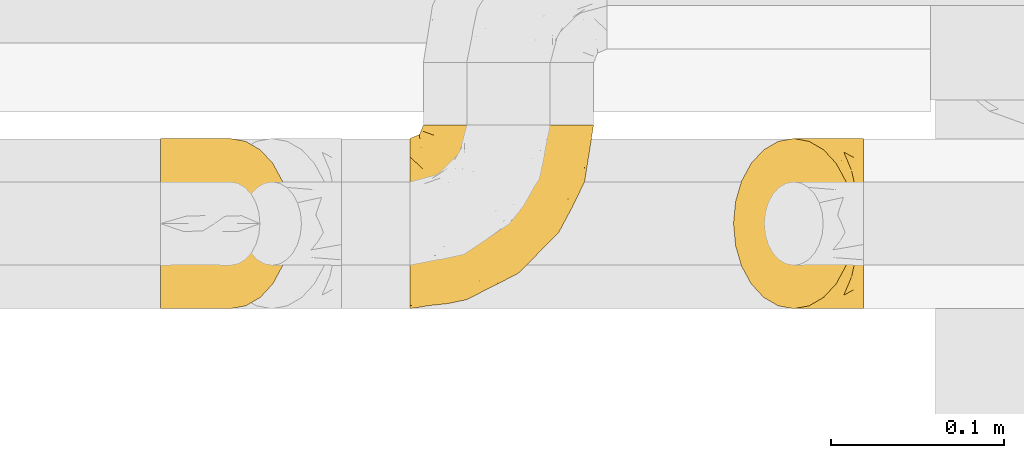
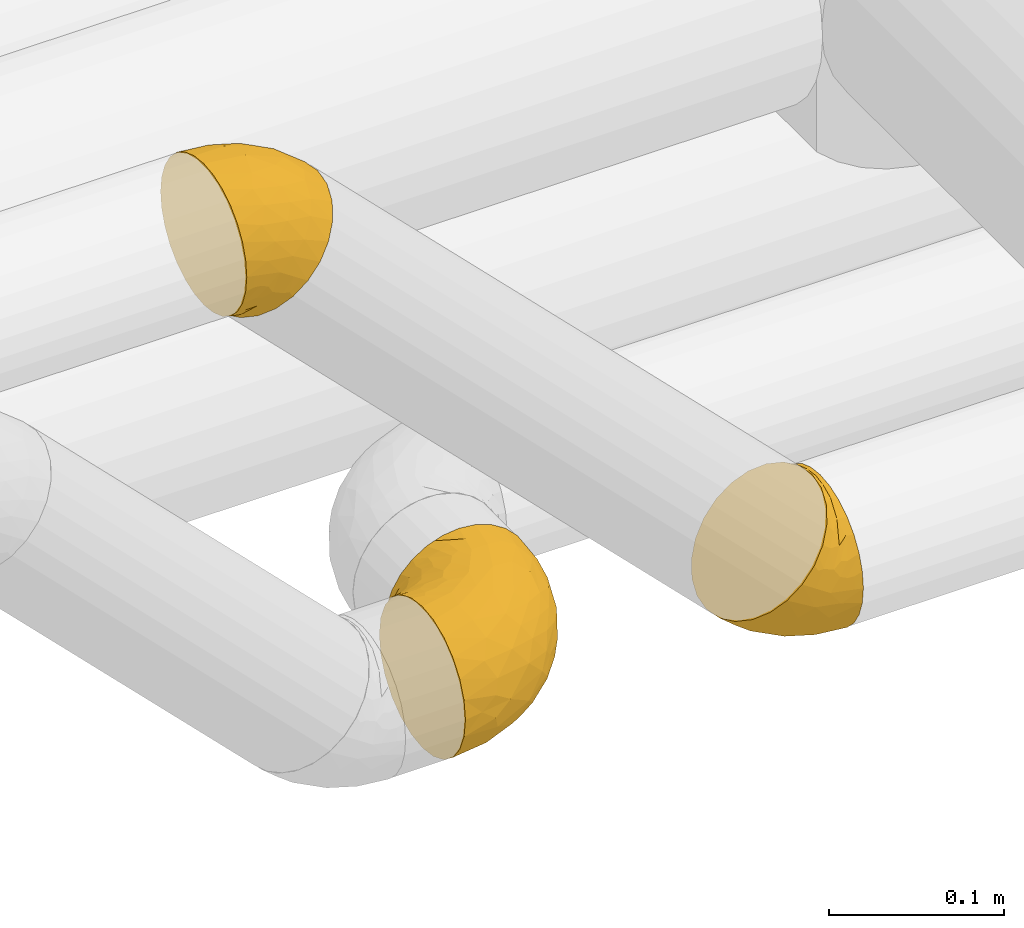
# One storey, part 31 of 93: 3 coverings.
"""IFC2X3 building model written with IfcOpenShell, lengths in millimetres."""

from ifc_helpers import new_model, entity, si_unit, converted_unit, derived_unit, direction, frame, origin, place, context, subcontext, project, spatial, faceted_brep, element, save


model = new_model("IFC2X3")

# Units and contexts
model_context = context("Model", 3, precision=0.01, world=origin(), true_north=direction((6.12303176911189e-17, 1.0)))
body_context = subcontext(model_context, "Body", "Model", "MODEL_VIEW")
ifc_project = project(units=[si_unit("LENGTHUNIT", "METRE", prefix="MILLI"), si_unit("AREAUNIT", "SQUARE_METRE"), si_unit("VOLUMEUNIT", "CUBIC_METRE"), converted_unit("PLANEANGLEUNIT", "DEGREE", entity("IfcRatioMeasure", 0.0174532925199433), si_unit("PLANEANGLEUNIT", "RADIAN"), dimensions=[0, 0, 0, 0, 0, 0, 0]), si_unit("MASSUNIT", "GRAM", prefix="KILO"), derived_unit("MASSDENSITYUNIT", [(si_unit("MASSUNIT", "GRAM", prefix="KILO"), 1), (si_unit("LENGTHUNIT", "METRE"), -3)]), derived_unit("MOMENTOFINERTIAUNIT", [(si_unit("LENGTHUNIT", "METRE"), 4)]), si_unit("TIMEUNIT", "SECOND"), si_unit("FREQUENCYUNIT", "HERTZ"), si_unit("THERMODYNAMICTEMPERATUREUNIT", "DEGREE_CELSIUS"), derived_unit("THERMALTRANSMITTANCEUNIT", [(si_unit("MASSUNIT", "GRAM", prefix="KILO"), 1), (si_unit("THERMODYNAMICTEMPERATUREUNIT", "KELVIN"), -1), (si_unit("TIMEUNIT", "SECOND"), -3)]), derived_unit("VOLUMETRICFLOWRATEUNIT", [(si_unit("LENGTHUNIT", "METRE"), 3), (si_unit("TIMEUNIT", "SECOND"), -1)]), derived_unit("MASSFLOWRATEUNIT", [(si_unit("MASSUNIT", "GRAM", prefix="KILO"), 1), (si_unit("TIMEUNIT", "SECOND"), -1)]), derived_unit("ROTATIONALFREQUENCYUNIT", [(si_unit("TIMEUNIT", "SECOND"), -1)]), si_unit("ELECTRICCURRENTUNIT", "AMPERE"), si_unit("ELECTRICVOLTAGEUNIT", "VOLT"), si_unit("POWERUNIT", "WATT"), si_unit("FORCEUNIT", "NEWTON", prefix="KILO"), si_unit("ILLUMINANCEUNIT", "LUX"), si_unit("LUMINOUSFLUXUNIT", "LUMEN"), si_unit("LUMINOUSINTENSITYUNIT", "CANDELA"), derived_unit("USERDEFINED", [(si_unit("MASSUNIT", "GRAM", prefix="KILO"), -1), (si_unit("LENGTHUNIT", "METRE"), -2), (si_unit("TIMEUNIT", "SECOND"), 3), (si_unit("LUMINOUSFLUXUNIT", "LUMEN"), 1)]), derived_unit("LINEARVELOCITYUNIT", [(si_unit("LENGTHUNIT", "METRE"), 1), (si_unit("TIMEUNIT", "SECOND"), -1)]), si_unit("PRESSUREUNIT", "PASCAL"), derived_unit("USERDEFINED", [(si_unit("LENGTHUNIT", "METRE"), -2), (si_unit("MASSUNIT", "GRAM", prefix="KILO"), 1), (si_unit("TIMEUNIT", "SECOND"), -2)]), derived_unit("LINEARFORCEUNIT", [(si_unit("MASSUNIT", "GRAM", prefix="KILO"), 1), (si_unit("LENGTHUNIT", "METRE"), 1), (si_unit("TIMEUNIT", "SECOND"), -2), (si_unit("LENGTHUNIT", "METRE"), -1)]), derived_unit("PLANARFORCEUNIT", [(si_unit("MASSUNIT", "GRAM", prefix="KILO"), 1), (si_unit("LENGTHUNIT", "METRE"), 1), (si_unit("TIMEUNIT", "SECOND"), -2), (si_unit("LENGTHUNIT", "METRE"), -2)])], contexts=[model_context])

# Site, building, storey
site_placement = place(None, origin())
site = spatial("IfcSite", under=ifc_project, at=site_placement, CompositionType="ELEMENT")
building_placement = place(site_placement, origin())
building = spatial("IfcBuilding", under=site, at=building_placement, CompositionType="ELEMENT")
storey_placement = place(building_placement, frame((0.0, 0.0, -4200.0)))
storey = spatial("IfcBuildingStorey", under=building, at=storey_placement, CompositionType="ELEMENT", Elevation=-4200.0)

# Coverings
covering_1_placement = place(storey_placement, frame((23794.45, 8660.4, 2649.25)))
element("IfcCovering", 1, at=covering_1_placement, inside=storey, Name=":ADSK_", ObjectType=":ADSK_", PredefinedType="INSULATION", context=body_context, shape_type="Brep", body=[
    faceted_brep([(58.6, 107.75, 99.9), (69.54, 107.75, 98.66), (79.93, 107.75, 95.02), (89.25, 107.75, 89.17), (97.03, 107.75, 81.38), (102.88, 107.75, 72.06), (106.51, 107.75, 61.68), (107.75, 107.75, 50.75), (106.51, 107.75, 39.8), (102.87, 107.75, 29.41), (97.02, 107.75, 20.09), (89.23, 107.75, 12.31), (79.91, 107.75, 6.46), (69.53, 107.75, 2.83), (58.6, 107.75, 1.6), (52.89, 107.75, 2.24), (47.65, 107.75, 2.83), (42.46, 107.75, 4.65), (37.26, 107.75, 6.47), (27.94, 107.75, 12.32), (20.16, 107.75, 20.11), (14.31, 107.75, 29.43), (10.68, 107.75, 39.81), (9.45, 107.75, 50.75), (10.68, 107.75, 61.69), (14.32, 107.75, 72.08), (20.17, 107.75, 81.4), (27.96, 107.75, 89.18), (37.28, 107.75, 95.03), (42.47, 107.75, 96.85), (47.66, 107.75, 98.66), (52.89, 107.75, 99.25), (55.75, 107.75, 99.57), (1.6, 98.22, 38.02), (1.6, 93.31, 26.17), (1.6, 89.4, 21.08), (1.6, 85.5, 15.99), (1.6, 80.41, 12.09), (1.6, 75.32, 8.18), (1.6, 69.39, 5.73), (1.6, 63.47, 3.27), (1.6, 56.48, 2.35), (1.6, 53.61, 1.97), (1.6, 50.75, 1.6), (1.6, 38.02, 3.27), (1.6, 26.17, 8.18), (1.6, 15.99, 15.99), (1.6, 8.18, 26.17), (1.6, 3.27, 38.02), (1.6, 1.6, 50.75), (1.6, 3.27, 63.47), (1.6, 8.18, 75.32), (1.6, 15.99, 85.5), (1.6, 26.17, 93.31), (1.6, 38.02, 98.22), (1.6, 50.75, 99.9), (1.6, 56.48, 99.14), (1.6, 63.47, 98.22), (1.6, 69.39, 95.77), (1.6, 75.32, 93.31), (1.6, 80.41, 89.4), (1.6, 85.5, 85.5), (1.6, 89.4, 80.41), (1.6, 93.31, 75.32), (1.6, 98.22, 63.47), (1.6, 99.9, 50.75), (69.96, 27.53, 59.31), (59.59, 25.32, 73.08), (51.96, 16.29, 63.72), (34.4, 6.79, 50.75), (23.37, 4.51, 58.64), (13.68, 3.51, 50.75), (41.52, 17.47, 76.74), (26.26, 7.6, 67.68), (20.18, 12.27, 78.92), (72.33, 70.89, 94.31), (65.88, 87.17, 98.76), (57.55, 67.3, 98.4), (23.76, 31.65, 94.57), (46.5, 33.58, 89.91), (46.57, 47.23, 96.32), (21.17, 43.26, 98.79), (23.41, 55.08, 99.9), (17.92, 53.99, 99.9), (12.43, 52.9, 99.9), (9.72, 52.36, 99.9), (7.01, 51.82, 99.9), (26.77, 21.5, 87.31), (76.59, 89.94, 95.61), (95.55, 60.45, 60.43), (102.57, 83.0, 65.24), (92.89, 64.79, 72.87), (54.26, 85.93, 99.9), (51.17, 81.31, 99.9), (48.08, 76.69, 99.9), (44.99, 72.06, 99.9), (41.9, 67.44, 99.9), (85.16, 88.74, 90.65), (85.97, 45.98, 63.14), (59.58, 47.13, 91.89), (99.5, 89.4, 75.25), (105.83, 95.66, 50.75), (53.59, 28.5, 82.18), (67.0, 42.81, 85.08), (71.56, 38.28, 76.93), (87.47, 45.35, 50.75), (75.73, 33.61, 50.75), (92.24, 82.57, 83.02), (58.06, 105.04, 99.9), (57.52, 102.33, 99.9), (56.44, 96.91, 99.9), (55.35, 91.42, 99.9), (81.33, 65.92, 87.13), (80.35, 53.11, 80.85), (39.44, 54.37, 99.17), (102.55, 74.94, 50.75), (37.28, 64.35, 99.9), (32.65, 61.26, 99.9), (28.03, 58.17, 99.9), (63.99, 21.87, 50.75), (74.55, 34.79, 67.61), (83.62, 48.48, 72.25), (95.01, 60.15, 50.75), (49.19, 14.33, 50.75), (46.96, 99.07, 98.69), (8.77, 60.55, 99.01), (18.28, 64.18, 98.79), (11.68, 64.36, 98.29), (11.79, 103.17, 68.51), (15.69, 101.69, 76.82), (42.49, 87.75, 98.54), (47.41, 89.38, 99.3), (7.94, 88.34, 83.57), (9.27, 82.14, 89.47), (7.98, 94.51, 75.76), (13.4, 89.64, 84.86), (13.04, 98.41, 75.89), (7.36, 99.71, 64.77), (23.46, 89.37, 90.83), (30.46, 88.21, 94.62), (26.54, 95.2, 90.37), (6.76, 79.14, 91.18), (26.46, 101.22, 88.65), (20.77, 99.41, 84.11), (20.68, 84.72, 91.75), (40.26, 97.47, 96.86), (7.15, 102.19, 50.75), (9.28, 104.02, 58.97), (38.78, 82.66, 98.37), (18.27, 95.42, 83.91), (31.78, 78.67, 97.52), (12.75, 72.69, 95.55), (22.96, 66.46, 98.76), (17.55, 75.3, 95.26), (27.63, 72.74, 98.04), (15.23, 82.93, 90.65), (33.25, 99.27, 93.51), (32.43, 93.51, 94.16), (27.9, 67.35, 99.1), (7.97, 94.51, 25.73), (15.22, 82.94, 10.84), (7.93, 88.33, 17.92), (13.38, 89.64, 16.64), (13.12, 103.62, 30.44), (42.49, 87.74, 2.95), (47.4, 89.38, 2.19), (51.17, 81.31, 1.6), (40.24, 97.47, 4.63), (20.76, 99.41, 17.39), (12.43, 52.9, 1.6), (7.01, 51.82, 1.6), (4.31, 51.28, 1.6), (26.44, 101.21, 12.86), (26.52, 95.19, 11.13), (11.68, 64.36, 3.2), (12.75, 72.69, 5.94), (9.27, 82.13, 12.02), (17.55, 75.3, 6.23), (6.76, 79.14, 10.31), (33.21, 99.28, 8.0), (32.41, 93.51, 7.34), (8.77, 60.55, 2.48), (22.96, 66.46, 2.73), (18.48, 63.96, 2.64), (56.44, 96.91, 1.6), (46.95, 99.06, 2.8), (7.36, 99.7, 36.71), (17.92, 53.99, 1.6), (23.41, 55.08, 1.6), (9.85, 103.3, 38.59), (57.52, 102.33, 1.6), (56.98, 99.62, 1.6), (48.08, 76.69, 1.6), (38.78, 82.66, 3.12), (18.25, 95.42, 17.59), (44.99, 72.06, 1.6), (31.74, 78.68, 3.98), (30.45, 88.2, 6.87), (27.63, 72.75, 3.45), (20.65, 84.74, 9.76), (55.35, 91.42, 1.6), (54.26, 85.93, 1.6), (13.03, 98.41, 25.62), (23.44, 89.37, 10.67), (27.9, 67.35, 2.39), (32.65, 61.26, 1.6), (28.03, 58.17, 1.6), (37.28, 64.35, 1.6), (41.9, 67.44, 1.6), (39.74, 54.08, 2.4), (23.37, 4.51, 42.85), (26.77, 21.5, 14.18), (46.18, 33.43, 11.56), (53.54, 28.5, 19.27), (41.53, 17.47, 24.75), (59.61, 25.36, 28.37), (76.79, 90.18, 5.95), (66.11, 86.97, 2.79), (21.17, 43.26, 2.71), (51.96, 16.29, 37.78), (26.26, 7.6, 33.81), (20.18, 12.27, 22.57), (23.76, 31.65, 6.92), (92.88, 64.79, 28.61), (102.57, 83.0, 36.24), (95.54, 60.44, 41.05), (71.63, 38.35, 24.55), (74.55, 34.8, 33.88), (72.51, 71.54, 7.11), (69.96, 27.53, 42.18), (92.23, 82.57, 18.46), (85.15, 88.74, 10.84), (80.45, 53.19, 20.69), (83.65, 48.49, 29.27), (57.57, 67.28, 3.1), (63.68, 52.32, 9.18), (85.95, 45.94, 38.38), (99.49, 89.4, 26.23), (81.23, 65.75, 14.34), (47.07, 46.73, 5.46), (66.99, 42.82, 16.39)], [[[0, 1, 2, 3, 4, 5, 6, 7, 8, 9, 10, 11, 12, 13, 14, 15, 16, 17, 18, 19, 20, 21, 22, 23, 24, 25, 26, 27, 28, 29, 30, 31, 32]], [[33, 34, 35, 36, 37, 38, 39, 40, 41, 42, 43, 44, 45, 46, 47, 48, 49, 50, 51, 52, 53, 54, 55, 56, 57, 58, 59, 60, 61, 62, 63, 64, 65]], [[66, 67, 68]], [[69, 70, 71]], [[68, 72, 73]], [[73, 72, 74]], [[75, 76, 77]], [[78, 79, 80]], [[51, 50, 73]], [[81, 82, 83, 84, 85, 86, 55]], [[52, 87, 53]], [[74, 52, 51]], [[2, 1, 88]], [[89, 90, 91]], [[77, 92, 93, 94, 95, 96]], [[55, 54, 81]], [[78, 53, 87]], [[5, 90, 6]], [[88, 76, 75]], [[97, 3, 2]], [[89, 91, 98]], [[99, 80, 79]], [[90, 5, 100]], [[74, 87, 52]], [[100, 5, 4]], [[90, 101, 6]], [[79, 102, 103]], [[102, 67, 104]], [[105, 98, 106]], [[107, 4, 3]], [[76, 0, 108, 109, 110, 111, 92]], [[107, 112, 113]], [[114, 77, 96]], [[89, 115, 90]], [[114, 96, 116, 117, 118, 82]], [[75, 97, 88]], [[119, 66, 68]], [[50, 71, 70]], [[100, 91, 90]], [[99, 77, 80]], [[102, 104, 103]], [[97, 107, 3]], [[80, 81, 78]], [[107, 97, 112]], [[68, 73, 70]], [[66, 98, 120]], [[78, 81, 54]], [[114, 81, 80]], [[53, 78, 54]], [[78, 87, 79]], [[102, 87, 72]], [[79, 103, 99]], [[4, 107, 100]], [[91, 100, 107]], [[88, 97, 2]], [[112, 97, 75]], [[99, 112, 75]], [[103, 104, 113]], [[91, 121, 98]], [[89, 105, 122, 115]], [[101, 90, 115]], [[101, 7, 6]], [[88, 1, 76]], [[0, 76, 1]], [[92, 77, 76]], [[73, 74, 51]], [[87, 74, 72]], [[81, 114, 82]], [[77, 114, 80]], [[87, 102, 79]], [[67, 102, 72]], [[68, 67, 72]], [[67, 120, 104]], [[120, 121, 104]], [[104, 121, 113]], [[121, 120, 98]], [[91, 107, 113]], [[91, 113, 121]], [[103, 113, 112]], [[106, 98, 66]], [[105, 89, 98]], [[106, 66, 119]], [[67, 66, 120]], [[68, 69, 123, 119]], [[50, 49, 71]], [[50, 70, 73]], [[112, 99, 103]], [[77, 99, 75]], [[69, 68, 70]], [[29, 124, 110]], [[84, 83, 125]], [[126, 82, 118]], [[59, 58, 127]], [[25, 128, 129]], [[130, 93, 131]], [[132, 62, 133]], [[134, 135, 136]], [[137, 65, 64]], [[64, 134, 137]], [[138, 139, 140]], [[111, 110, 124, 92]], [[134, 136, 137]], [[134, 64, 63]], [[141, 61, 60]], [[125, 58, 57]], [[142, 143, 140]], [[142, 26, 143]], [[127, 83, 82]], [[28, 124, 29]], [[108, 0, 32, 31, 30, 110, 109]], [[30, 29, 110]], [[135, 144, 138]], [[28, 145, 124]], [[57, 56, 55, 86, 85, 84]], [[146, 147, 23]], [[24, 23, 147]], [[25, 143, 26]], [[95, 94, 148]], [[24, 128, 25]], [[149, 138, 143]], [[124, 145, 131]], [[127, 58, 125]], [[150, 148, 139]], [[127, 126, 151]], [[151, 59, 127]], [[152, 151, 126]], [[153, 154, 155]], [[153, 133, 141]], [[145, 28, 27]], [[142, 156, 27]], [[157, 148, 130]], [[61, 133, 62]], [[134, 132, 135]], [[147, 128, 24]], [[65, 137, 146]], [[146, 137, 147]], [[128, 137, 136]], [[137, 128, 147]], [[128, 136, 129]], [[149, 129, 136]], [[25, 129, 143]], [[158, 152, 117]], [[152, 118, 117]], [[153, 151, 152]], [[158, 116, 154]], [[144, 150, 138]], [[153, 152, 158]], [[133, 153, 155]], [[133, 155, 132]], [[60, 151, 141]], [[135, 132, 155]], [[134, 63, 132]], [[144, 135, 155]], [[135, 138, 149]], [[155, 154, 144]], [[150, 154, 96]], [[154, 150, 144]], [[148, 94, 130]], [[82, 126, 127]], [[118, 152, 126]], [[150, 96, 95]], [[139, 148, 157]], [[150, 95, 148]], [[93, 92, 131]], [[130, 145, 156]], [[130, 94, 93]], [[84, 125, 57]], [[127, 125, 83]], [[140, 139, 157]], [[150, 139, 138]], [[140, 157, 142]], [[138, 140, 143]], [[156, 142, 157]], [[27, 26, 142]], [[130, 156, 157]], [[145, 27, 156]], [[132, 63, 62]], [[124, 131, 92]], [[130, 131, 145]], [[129, 149, 143]], [[135, 149, 136]], [[141, 133, 61]], [[60, 59, 151]], [[141, 151, 153]], [[116, 96, 154]], [[153, 158, 154]], [[158, 117, 116]], [[34, 33, 159]], [[160, 161, 162]], [[22, 21, 163]], [[164, 165, 166]], [[19, 18, 167]], [[168, 21, 20]], [[42, 41, 40, 169, 170, 171, 43]], [[172, 173, 168]], [[174, 38, 175]], [[176, 177, 178]], [[179, 164, 180]], [[40, 181, 169]], [[182, 183, 175]], [[17, 184, 185]], [[65, 146, 186]], [[187, 174, 188]], [[23, 22, 189]], [[174, 39, 38]], [[15, 14, 190, 191, 184, 16]], [[181, 40, 39]], [[192, 193, 164]], [[194, 163, 168]], [[33, 186, 159]], [[180, 173, 172]], [[195, 196, 193]], [[18, 185, 167]], [[173, 180, 197]], [[198, 199, 196]], [[200, 201, 185, 184]], [[184, 17, 16]], [[18, 17, 185]], [[202, 159, 186]], [[194, 168, 203]], [[189, 163, 202]], [[204, 205, 182]], [[187, 181, 174]], [[160, 177, 176]], [[206, 183, 182]], [[206, 182, 205]], [[201, 165, 185]], [[165, 164, 167]], [[172, 179, 180]], [[202, 194, 162]], [[176, 161, 160]], [[65, 186, 33]], [[163, 189, 22]], [[175, 177, 182]], [[174, 183, 188]], [[177, 198, 204]], [[199, 160, 162]], [[198, 207, 204]], [[175, 38, 37]], [[198, 177, 160]], [[178, 177, 175]], [[176, 35, 161]], [[34, 159, 161]], [[162, 161, 159]], [[202, 162, 159]], [[199, 162, 203]], [[196, 199, 203]], [[198, 160, 199]], [[193, 197, 180]], [[208, 198, 196]], [[188, 183, 206]], [[175, 183, 174]], [[193, 192, 195]], [[195, 208, 196]], [[197, 196, 203]], [[180, 164, 193]], [[168, 163, 21]], [[166, 165, 201]], [[166, 192, 164]], [[189, 202, 186]], [[186, 146, 189]], [[23, 189, 146]], [[174, 181, 39]], [[169, 181, 187]], [[196, 197, 193]], [[173, 203, 168]], [[203, 173, 197]], [[172, 168, 20]], [[20, 19, 172]], [[179, 172, 19]], [[19, 167, 179]], [[164, 179, 167]], [[35, 176, 36]], [[35, 34, 161]], [[185, 165, 167]], [[162, 194, 203]], [[163, 194, 202]], [[176, 178, 36]], [[37, 36, 178]], [[175, 37, 178]], [[177, 204, 182]], [[207, 198, 208]], [[207, 205, 204]], [[209, 188, 206, 205, 207, 208]], [[48, 210, 71]], [[211, 212, 213]], [[214, 213, 215]], [[216, 217, 13]], [[218, 43, 171, 170, 169, 187, 188]], [[219, 220, 214]], [[47, 46, 221]], [[210, 48, 220]], [[211, 222, 212]], [[222, 45, 44]], [[221, 220, 47]], [[47, 220, 48]], [[221, 211, 214]], [[223, 224, 225]], [[211, 46, 45]], [[226, 227, 215]], [[43, 218, 44]], [[217, 216, 228]], [[219, 215, 229]], [[14, 13, 217]], [[224, 9, 8]], [[10, 230, 11]], [[11, 231, 12]], [[232, 223, 233]], [[234, 208, 195, 192, 166, 201]], [[235, 234, 228]], [[222, 44, 218]], [[106, 229, 236]], [[224, 237, 9]], [[231, 238, 228]], [[9, 237, 10]], [[115, 224, 101]], [[239, 234, 235]], [[231, 11, 230]], [[223, 230, 237]], [[224, 8, 101]], [[223, 236, 233]], [[225, 115, 122, 105]], [[216, 12, 231]], [[209, 234, 239]], [[210, 219, 69]], [[219, 214, 215]], [[229, 119, 219]], [[209, 218, 188]], [[239, 212, 222]], [[239, 222, 218]], [[45, 222, 211]], [[235, 212, 239]], [[213, 212, 240]], [[223, 237, 224]], [[230, 10, 237]], [[238, 231, 230]], [[216, 231, 228]], [[232, 230, 223]], [[235, 238, 240]], [[115, 225, 224]], [[233, 236, 227]], [[8, 7, 101]], [[234, 209, 208]], [[218, 209, 239]], [[217, 228, 234]], [[13, 12, 216]], [[234, 201, 217]], [[217, 201, 200, 184, 191, 190, 14]], [[211, 221, 46]], [[220, 221, 214]], [[71, 210, 69]], [[71, 49, 48]], [[219, 210, 220]], [[226, 215, 213]], [[211, 213, 214]], [[226, 213, 240]], [[215, 227, 229]], [[232, 240, 238]], [[233, 227, 226]], [[232, 233, 226]], [[236, 223, 225]], [[240, 232, 226]], [[232, 238, 230]], [[225, 105, 236]], [[236, 105, 106]], [[236, 229, 227]], [[123, 69, 219, 119]], [[106, 119, 229]], [[238, 235, 228]], [[212, 235, 240]]]),
])
covering_2_placement = place(storey_placement, frame((23650.45, 8660.4, 3005.76)))
element("IfcCovering", 2, at=covering_2_placement, inside=storey, Name=":ADSK_", ObjectType=":ADSK_", PredefinedType="INSULATION", context=body_context, shape_type="Brep", body=[
    faceted_brep([(1.6, 50.75, 3.89), (1.6, 39.8, 5.13), (1.6, 29.41, 8.77), (1.6, 20.09, 14.62), (1.6, 12.31, 22.41), (1.6, 6.46, 31.73), (1.6, 2.83, 42.11), (1.6, 1.6, 53.04), (1.6, 2.83, 63.99), (1.6, 6.47, 74.38), (1.6, 12.32, 83.7), (1.6, 20.11, 91.48), (1.6, 29.43, 97.33), (1.6, 39.81, 100.96), (1.6, 50.75, 102.19), (1.6, 61.69, 100.96), (1.6, 72.08, 97.32), (1.6, 81.4, 91.47), (1.6, 89.18, 83.68), (1.6, 95.03, 74.36), (1.6, 98.66, 63.98), (1.6, 99.9, 53.04), (1.6, 98.66, 42.1), (1.6, 95.02, 31.71), (1.6, 89.17, 22.39), (1.6, 81.38, 14.61), (1.6, 72.06, 8.76), (1.6, 61.68, 5.13), (8.33, 63.47, 2.78), (11.8, 75.32, 6.25), (17.33, 85.5, 11.77), (24.52, 93.31, 18.97), (32.91, 98.22, 27.35), (35.62, 98.73, 30.07), (41.9, 99.9, 36.35), (50.9, 98.22, 45.34), (59.28, 93.31, 53.73), (66.48, 85.5, 60.92), (72.0, 75.32, 66.45), (75.47, 63.47, 69.92), (76.65, 50.75, 71.1), (75.47, 38.02, 69.92), (72.0, 26.17, 66.45), (66.48, 15.99, 60.92), (59.28, 8.18, 53.73), (50.9, 3.27, 45.34), (41.9, 1.6, 36.35), (35.62, 2.76, 30.07), (32.91, 3.27, 27.35), (28.71, 5.73, 23.16), (24.52, 8.18, 18.97), (17.33, 15.99, 11.77), (11.8, 26.17, 6.25), (8.33, 38.02, 2.78), (7.15, 50.75, 1.6), (22.47, 17.06, 86.45), (54.67, 50.75, 87.97), (62.68, 42.16, 81.93), (55.4, 21.74, 76.36), (58.06, 32.73, 81.87), (39.2, 26.38, 88.36), (50.71, 13.88, 70.88), (43.39, 40.98, 92.55), (33.67, 10.72, 75.33), (40.0, 18.26, 81.72), (22.29, 5.11, 68.4), (42.19, 6.1, 62.14), (32.54, 2.75, 56.16), (16.07, 2.16, 58.8), (23.41, 1.6, 48.71), (19.48, 25.58, 93.64), (24.45, 35.33, 97.16), (29.07, 50.75, 98.58), (16.3, 9.83, 78.98), (28.06, 1.6, 45.6), (32.71, 1.6, 42.49), (35.01, 1.6, 40.95), (37.31, 1.6, 39.42), (7.01, 1.6, 51.97), (12.43, 1.6, 50.89), (17.92, 1.6, 49.8), (5.82, 31.89, 6.86), (19.85, 3.63, 35.0), (26.57, 3.42, 31.94), (16.36, 2.64, 40.6), (14.25, 5.35, 32.05), (8.46, 19.98, 13.41), (14.01, 14.31, 16.6), (12.95, 9.44, 24.2), (30.54, 2.88, 31.56), (6.92, 2.5, 43.37), (11.71, 2.44, 42.87), (5.12, 41.56, 4.01), (19.42, 8.24, 23.01), (6.71, 12.78, 21.32), (9.96, 5.31, 33.36), (4.6, 50.75, 3.3), (14.01, 87.18, 16.6), (8.45, 81.5, 13.4), (19.42, 93.25, 23.01), (5.12, 59.93, 4.01), (5.82, 69.59, 6.85), (7.01, 99.9, 51.97), (12.94, 92.03, 24.17), (37.31, 99.9, 39.42), (31.44, 99.1, 33.9), (6.71, 88.7, 21.3), (26.57, 98.07, 31.94), (23.41, 99.9, 48.71), (19.84, 97.86, 34.99), (16.36, 98.85, 40.59), (28.06, 99.9, 45.6), (9.96, 96.17, 33.34), (12.43, 99.9, 50.89), (6.93, 98.99, 43.38), (11.7, 99.04, 42.85), (14.25, 96.14, 32.03), (17.92, 99.9, 49.8), (32.71, 99.9, 42.49), (22.29, 96.38, 68.39), (32.54, 98.74, 56.15), (22.47, 84.45, 86.44), (42.19, 95.4, 62.12), (33.66, 90.78, 75.32), (55.02, 60.07, 86.73), (58.05, 68.76, 81.87), (55.41, 79.75, 76.36), (39.2, 75.13, 88.35), (16.07, 99.34, 58.8), (50.71, 87.61, 70.88), (16.3, 91.67, 78.97), (42.49, 65.98, 91.37), (24.46, 66.17, 97.16), (19.48, 75.92, 93.63), (40.0, 83.22, 81.72)], [[[0, 1, 2, 3, 4, 5, 6, 7, 8, 9, 10, 11, 12, 13, 14, 15, 16, 17, 18, 19, 20, 21, 22, 23, 24, 25, 26, 27]], [[28, 29, 30, 31, 32, 33, 34, 35, 36, 37, 38, 39, 40, 41, 42, 43, 44, 45, 46, 47, 48, 49, 50, 51, 52, 53, 54]], [[10, 55, 11]], [[40, 56, 57]], [[42, 58, 43]], [[59, 60, 58]], [[61, 44, 43]], [[60, 59, 62]], [[63, 61, 64]], [[63, 65, 66]], [[67, 46, 45]], [[66, 67, 45]], [[42, 41, 59]], [[67, 68, 69]], [[58, 61, 43]], [[70, 60, 71]], [[71, 62, 72]], [[72, 13, 71]], [[55, 70, 11]], [[12, 70, 71]], [[59, 58, 42]], [[14, 13, 72]], [[73, 55, 10]], [[67, 69, 74, 75, 76, 77, 46]], [[41, 57, 59]], [[68, 7, 78, 79, 80, 69]], [[9, 8, 65]], [[73, 65, 63]], [[45, 44, 66]], [[67, 66, 65]], [[9, 73, 10]], [[57, 62, 59]], [[68, 65, 8]], [[12, 71, 13]], [[60, 55, 64]], [[66, 44, 61]], [[64, 61, 58]], [[61, 63, 66]], [[60, 64, 58]], [[63, 64, 55]], [[65, 73, 9]], [[55, 73, 63]], [[65, 68, 67]], [[7, 68, 8]], [[11, 70, 12]], [[55, 60, 70]], [[40, 57, 41]], [[62, 57, 56]], [[72, 62, 56]], [[62, 71, 60]], [[52, 81, 53]], [[82, 83, 74]], [[84, 85, 82]], [[86, 87, 88]], [[77, 89, 48]], [[87, 52, 51]], [[90, 5, 91]], [[92, 1, 0]], [[86, 2, 81]], [[54, 53, 92]], [[52, 86, 81]], [[93, 51, 50]], [[87, 51, 93]], [[83, 93, 50]], [[94, 95, 4]], [[5, 4, 95]], [[5, 95, 91]], [[7, 6, 78]], [[94, 88, 85]], [[86, 94, 3]], [[48, 47, 46, 77]], [[96, 92, 0]], [[80, 91, 84]], [[2, 1, 81]], [[3, 2, 86]], [[90, 78, 6]], [[1, 92, 81]], [[94, 86, 88]], [[82, 93, 83]], [[3, 94, 4]], [[80, 84, 69]], [[82, 88, 93]], [[49, 48, 89]], [[69, 82, 74]], [[83, 75, 74]], [[88, 87, 93]], [[52, 87, 86]], [[91, 80, 79]], [[91, 79, 90]], [[84, 91, 95]], [[85, 84, 95]], [[69, 84, 82]], [[78, 90, 79]], [[5, 90, 6]], [[94, 85, 95]], [[82, 85, 88]], [[54, 92, 96]], [[81, 92, 53]], [[83, 89, 75]], [[77, 76, 75, 89]], [[83, 49, 89]], [[83, 50, 49]], [[97, 29, 98]], [[30, 99, 31]], [[100, 101, 28]], [[22, 21, 102]], [[103, 99, 97]], [[101, 29, 28]], [[104, 33, 105]], [[98, 106, 103]], [[107, 31, 99]], [[97, 99, 30]], [[108, 109, 110]], [[26, 98, 101]], [[54, 96, 100]], [[109, 111, 107]], [[0, 27, 100]], [[112, 106, 24]], [[101, 27, 26]], [[102, 113, 114]], [[105, 31, 107]], [[25, 98, 26]], [[24, 106, 25]], [[112, 24, 23]], [[106, 98, 25]], [[23, 22, 114]], [[112, 115, 110]], [[113, 115, 114]], [[29, 101, 98]], [[112, 116, 106]], [[29, 97, 30]], [[96, 0, 100]], [[115, 113, 117]], [[103, 109, 99]], [[109, 107, 99]], [[105, 107, 118]], [[111, 109, 108]], [[111, 118, 107]], [[103, 97, 98]], [[110, 116, 112]], [[110, 115, 117]], [[23, 115, 112]], [[108, 110, 117]], [[116, 109, 103]], [[23, 114, 115]], [[102, 114, 22]], [[109, 116, 110]], [[106, 116, 103]], [[104, 34, 33]], [[33, 32, 105]], [[101, 100, 27]], [[54, 100, 28]], [[104, 105, 118]], [[31, 105, 32]], [[20, 19, 119]], [[35, 34, 120]], [[120, 34, 104, 118, 111, 108]], [[121, 18, 17]], [[36, 35, 122]], [[122, 119, 123]], [[39, 124, 40]], [[125, 126, 127]], [[125, 39, 38]], [[128, 120, 108]], [[129, 36, 122]], [[38, 126, 125]], [[129, 126, 37]], [[37, 126, 38]], [[120, 128, 119]], [[35, 120, 122]], [[119, 19, 130]], [[131, 127, 132]], [[130, 19, 18]], [[133, 17, 16]], [[134, 127, 126]], [[123, 130, 121]], [[125, 127, 131]], [[16, 132, 133]], [[15, 14, 72]], [[72, 56, 124]], [[15, 72, 132]], [[133, 132, 127]], [[123, 129, 122]], [[15, 132, 16]], [[119, 122, 120]], [[128, 21, 20]], [[39, 125, 124]], [[126, 129, 134]], [[36, 129, 37]], [[134, 123, 121]], [[123, 134, 129]], [[127, 134, 121]], [[121, 130, 18]], [[119, 130, 123]], [[128, 108, 117, 113, 102, 21]], [[119, 128, 20]], [[127, 121, 133]], [[17, 133, 121]], [[72, 131, 132]], [[124, 125, 131]], [[72, 124, 131]], [[124, 56, 40]]]),
])
covering_3_placement = place(storey_placement, frame((23981.41, 8660.4, 2649.25)))
element("IfcCovering", 3, at=covering_3_placement, inside=storey, Name=":ADSK_", ObjectType=":ADSK_", PredefinedType="INSULATION", context=body_context, shape_type="Brep", body=[
    faceted_brep([(76.65, 39.8, 98.66), (76.65, 29.41, 95.02), (76.65, 20.09, 89.17), (76.65, 12.31, 81.38), (76.65, 6.46, 72.06), (76.65, 2.83, 61.68), (76.65, 1.6, 50.75), (76.65, 2.83, 39.8), (76.65, 6.47, 29.41), (76.65, 12.32, 20.09), (76.65, 20.11, 12.31), (76.65, 29.43, 6.46), (76.65, 39.81, 2.83), (76.65, 50.75, 1.6), (76.65, 61.69, 2.83), (76.65, 72.08, 6.47), (76.65, 81.4, 12.32), (76.65, 89.18, 20.11), (76.65, 95.03, 29.43), (76.65, 98.66, 39.81), (76.65, 99.9, 50.75), (76.65, 98.66, 61.69), (76.65, 95.02, 72.08), (76.65, 89.17, 81.4), (76.65, 81.38, 89.18), (76.65, 72.06, 95.03), (76.65, 61.68, 98.66), (76.65, 50.75, 99.9), (69.92, 63.47, 101.01), (66.45, 75.32, 97.54), (60.92, 85.5, 92.02), (53.73, 93.31, 84.82), (45.34, 98.22, 76.44), (42.63, 98.73, 73.72), (36.35, 99.9, 67.44), (27.35, 98.22, 58.45), (18.97, 93.31, 50.06), (11.77, 85.5, 42.87), (6.25, 75.32, 37.34), (2.78, 63.47, 33.87), (1.6, 50.75, 32.69), (2.78, 38.02, 33.87), (6.25, 26.17, 37.34), (11.77, 15.99, 42.87), (18.97, 8.18, 50.06), (27.35, 3.27, 58.45), (36.35, 1.6, 67.44), (42.63, 2.76, 73.72), (45.34, 3.27, 76.44), (49.54, 5.73, 80.63), (53.73, 8.18, 84.82), (60.92, 15.99, 92.02), (66.45, 26.17, 97.54), (69.92, 38.02, 101.01), (71.1, 50.75, 102.19), (55.78, 17.06, 17.34), (23.58, 50.75, 15.82), (15.57, 42.16, 21.86), (22.85, 21.74, 27.43), (20.19, 32.73, 21.92), (39.05, 26.38, 15.43), (27.54, 13.88, 32.91), (34.86, 40.98, 11.24), (44.58, 10.72, 28.46), (38.25, 18.26, 22.07), (55.96, 5.11, 35.39), (36.06, 6.1, 41.65), (45.71, 2.75, 47.63), (62.18, 2.16, 44.99), (54.84, 1.6, 55.08), (58.77, 25.58, 10.15), (53.8, 35.33, 6.63), (49.18, 50.75, 5.21), (61.94, 9.83, 24.81), (50.19, 1.6, 58.19), (45.54, 1.6, 61.3), (43.24, 1.6, 62.84), (40.94, 1.6, 64.37), (71.24, 1.6, 51.82), (65.82, 1.6, 52.9), (60.33, 1.6, 53.99), (72.43, 31.89, 96.93), (58.4, 3.63, 68.79), (51.68, 3.42, 71.85), (61.89, 2.64, 63.19), (64.0, 5.35, 71.74), (69.79, 19.98, 90.38), (64.24, 14.31, 87.19), (65.3, 9.44, 79.59), (47.71, 2.88, 72.23), (71.33, 2.5, 60.42), (66.54, 2.44, 60.92), (73.13, 41.56, 99.77), (58.83, 8.24, 80.78), (71.54, 12.78, 82.47), (68.29, 5.31, 70.43), (73.65, 50.75, 100.49), (64.24, 87.18, 87.19), (69.79, 81.5, 90.39), (58.83, 93.25, 80.78), (73.13, 59.93, 99.78), (72.43, 69.59, 96.94), (71.24, 99.9, 51.82), (65.31, 92.03, 79.62), (40.94, 99.9, 64.37), (46.81, 99.1, 69.89), (71.54, 88.7, 82.49), (51.68, 98.07, 71.85), (54.84, 99.9, 55.08), (58.41, 97.86, 68.8), (61.89, 98.85, 63.2), (50.19, 99.9, 58.19), (68.29, 96.17, 70.45), (65.82, 99.9, 52.9), (71.32, 98.99, 60.41), (66.55, 99.04, 60.94), (64.0, 96.14, 71.76), (60.33, 99.9, 53.99), (45.54, 99.9, 61.3), (55.96, 96.38, 35.4), (45.71, 98.74, 47.64), (55.78, 84.45, 17.35), (36.06, 95.4, 41.67), (44.59, 90.78, 28.47), (23.23, 60.07, 17.06), (20.2, 68.76, 21.92), (22.84, 79.75, 27.43), (39.05, 75.13, 15.44), (62.18, 99.34, 44.99), (27.54, 87.61, 32.91), (61.95, 91.67, 24.82), (35.76, 65.98, 12.42), (53.79, 66.17, 6.63), (58.77, 75.92, 10.16), (38.25, 83.22, 22.07)], [[[0, 1, 2, 3, 4, 5, 6, 7, 8, 9, 10, 11, 12, 13, 14, 15, 16, 17, 18, 19, 20, 21, 22, 23, 24, 25, 26, 27]], [[28, 29, 30, 31, 32, 33, 34, 35, 36, 37, 38, 39, 40, 41, 42, 43, 44, 45, 46, 47, 48, 49, 50, 51, 52, 53, 54]], [[9, 55, 10]], [[40, 56, 57]], [[42, 58, 43]], [[59, 60, 58]], [[61, 44, 43]], [[60, 59, 62]], [[63, 61, 64]], [[63, 65, 66]], [[67, 46, 45]], [[66, 67, 45]], [[42, 41, 59]], [[67, 68, 69]], [[58, 61, 43]], [[70, 60, 71]], [[71, 62, 72]], [[72, 12, 71]], [[55, 70, 10]], [[11, 70, 71]], [[59, 58, 42]], [[13, 12, 72]], [[73, 55, 9]], [[67, 69, 74, 75, 76, 77, 46]], [[41, 57, 59]], [[68, 6, 78, 79, 80, 69]], [[8, 7, 65]], [[73, 65, 63]], [[45, 44, 66]], [[67, 66, 65]], [[8, 73, 9]], [[57, 62, 59]], [[68, 65, 7]], [[11, 71, 12]], [[60, 55, 64]], [[66, 44, 61]], [[64, 61, 58]], [[61, 63, 66]], [[60, 64, 58]], [[63, 64, 55]], [[65, 73, 8]], [[55, 73, 63]], [[65, 68, 67]], [[6, 68, 7]], [[10, 70, 11]], [[55, 60, 70]], [[40, 57, 41]], [[62, 57, 56]], [[72, 62, 56]], [[62, 71, 60]], [[52, 81, 53]], [[82, 83, 74]], [[84, 85, 82]], [[86, 87, 88]], [[77, 89, 48]], [[87, 52, 51]], [[90, 4, 91]], [[92, 0, 27]], [[86, 1, 81]], [[54, 53, 92]], [[52, 86, 81]], [[93, 51, 50]], [[87, 51, 93]], [[83, 93, 50]], [[94, 95, 3]], [[4, 3, 95]], [[4, 95, 91]], [[6, 5, 78]], [[94, 88, 85]], [[86, 94, 2]], [[48, 47, 46, 77]], [[96, 92, 27]], [[80, 91, 84]], [[1, 0, 81]], [[2, 1, 86]], [[90, 78, 5]], [[0, 92, 81]], [[94, 86, 88]], [[82, 93, 83]], [[2, 94, 3]], [[80, 84, 69]], [[82, 88, 93]], [[49, 48, 89]], [[69, 82, 74]], [[83, 75, 74]], [[88, 87, 93]], [[52, 87, 86]], [[91, 80, 79]], [[91, 79, 90]], [[84, 91, 95]], [[85, 84, 95]], [[69, 84, 82]], [[78, 90, 79]], [[4, 90, 5]], [[94, 85, 95]], [[82, 85, 88]], [[54, 92, 96]], [[81, 92, 53]], [[83, 89, 75]], [[77, 76, 75, 89]], [[83, 49, 89]], [[83, 50, 49]], [[97, 29, 98]], [[30, 99, 31]], [[100, 101, 28]], [[21, 20, 102]], [[103, 99, 97]], [[101, 29, 28]], [[104, 33, 105]], [[98, 106, 103]], [[107, 31, 99]], [[97, 99, 30]], [[108, 109, 110]], [[25, 98, 101]], [[54, 96, 100]], [[109, 111, 107]], [[27, 26, 100]], [[112, 106, 23]], [[101, 26, 25]], [[102, 113, 114]], [[105, 31, 107]], [[24, 98, 25]], [[23, 106, 24]], [[112, 23, 22]], [[106, 98, 24]], [[22, 21, 114]], [[112, 115, 110]], [[113, 115, 114]], [[29, 101, 98]], [[112, 116, 106]], [[29, 97, 30]], [[96, 27, 100]], [[115, 113, 117]], [[103, 109, 99]], [[109, 107, 99]], [[105, 107, 118]], [[111, 109, 108]], [[111, 118, 107]], [[103, 97, 98]], [[110, 116, 112]], [[110, 115, 117]], [[22, 115, 112]], [[108, 110, 117]], [[116, 109, 103]], [[22, 114, 115]], [[102, 114, 21]], [[109, 116, 110]], [[106, 116, 103]], [[104, 34, 33]], [[33, 32, 105]], [[101, 100, 26]], [[54, 100, 28]], [[104, 105, 118]], [[31, 105, 32]], [[19, 18, 119]], [[35, 34, 120]], [[120, 34, 104, 118, 111, 108]], [[121, 17, 16]], [[36, 35, 122]], [[122, 119, 123]], [[39, 124, 40]], [[125, 126, 127]], [[125, 39, 38]], [[128, 120, 108]], [[129, 36, 122]], [[38, 126, 125]], [[129, 126, 37]], [[37, 126, 38]], [[120, 128, 119]], [[35, 120, 122]], [[119, 18, 130]], [[131, 127, 132]], [[130, 18, 17]], [[133, 16, 15]], [[134, 127, 126]], [[123, 130, 121]], [[125, 127, 131]], [[15, 132, 133]], [[14, 13, 72]], [[72, 56, 124]], [[14, 72, 132]], [[133, 132, 127]], [[123, 129, 122]], [[14, 132, 15]], [[119, 122, 120]], [[128, 20, 19]], [[39, 125, 124]], [[126, 129, 134]], [[36, 129, 37]], [[134, 123, 121]], [[123, 134, 129]], [[127, 134, 121]], [[121, 130, 17]], [[119, 130, 123]], [[128, 108, 117, 113, 102, 20]], [[119, 128, 19]], [[127, 121, 133]], [[16, 133, 121]], [[72, 131, 132]], [[124, 125, 131]], [[72, 124, 131]], [[124, 56, 40]]]),
])

save(model, "model.ifc")
